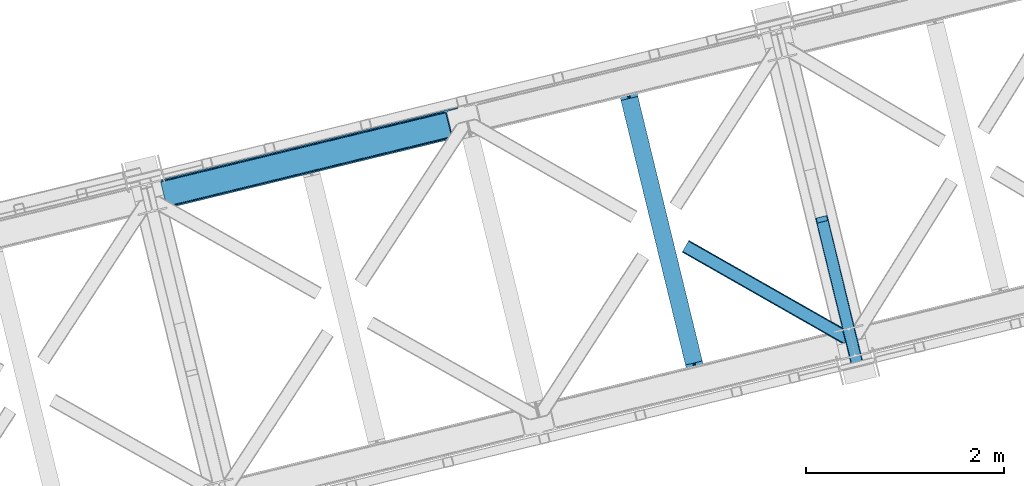
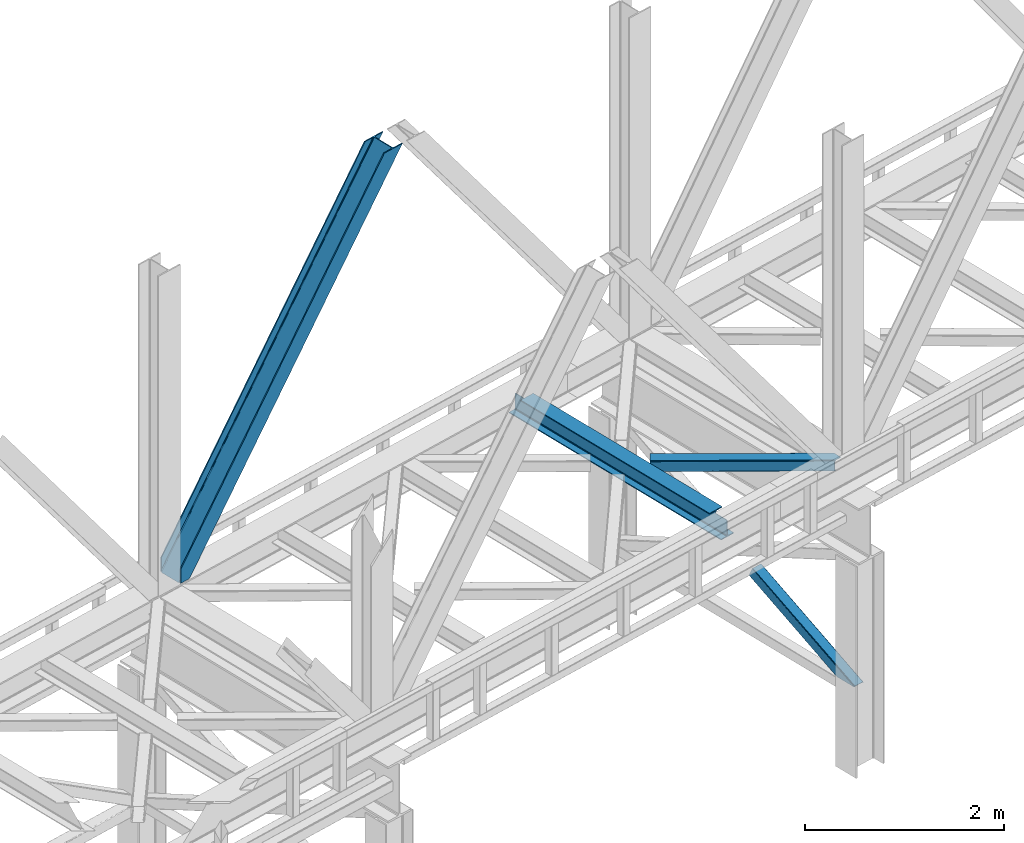
# One storey, part 54 of 93: 3 members, 1 beam.
"""IFC4 building model written with IfcOpenShell, lengths in millimetres."""

from ifc_helpers import new_model, entity, si_unit, converted_unit, derived_unit, direction, frame, origin, place, context, subcontext, project, spatial, triangles, polygons, material, type_object, element, save


model = new_model("IFC4")

# Units and contexts
model_context = context("Model", 3, precision=0.01, world=origin(), true_north=direction((6.12303176911189e-17, 1.0)))
plan_context = context("Plan", 3, precision=0.01, world=origin(), true_north=direction((6.12303176911189e-17, 1.0)))
body_context = subcontext(model_context, "Body", "Model", "MODEL_VIEW")
ifc_project = project(units=[si_unit("LENGTHUNIT", "METRE", prefix="MILLI"), si_unit("AREAUNIT", "SQUARE_METRE"), si_unit("VOLUMEUNIT", "CUBIC_METRE"), converted_unit("PLANEANGLEUNIT", "DEGREE", entity("IfcRatioMeasure", 0.0174532925199433), si_unit("PLANEANGLEUNIT", "RADIAN"), dimensions=[0, 0, 0, 0, 0, 0, 0]), si_unit("MASSUNIT", "GRAM", prefix="KILO"), derived_unit("MASSDENSITYUNIT", [(si_unit("MASSUNIT", "GRAM", prefix="KILO"), 1), (si_unit("LENGTHUNIT", "METRE"), -3)]), derived_unit("MOMENTOFINERTIAUNIT", [(si_unit("LENGTHUNIT", "METRE"), 4)]), si_unit("TIMEUNIT", "SECOND"), si_unit("FREQUENCYUNIT", "HERTZ"), si_unit("THERMODYNAMICTEMPERATUREUNIT", "DEGREE_CELSIUS"), derived_unit("THERMALTRANSMITTANCEUNIT", [(si_unit("MASSUNIT", "GRAM", prefix="KILO"), 1), (si_unit("THERMODYNAMICTEMPERATUREUNIT", "KELVIN"), -1), (si_unit("TIMEUNIT", "SECOND"), -3)]), derived_unit("VOLUMETRICFLOWRATEUNIT", [(si_unit("LENGTHUNIT", "METRE"), 3), (si_unit("TIMEUNIT", "SECOND"), -1)]), derived_unit("MASSFLOWRATEUNIT", [(si_unit("MASSUNIT", "GRAM", prefix="KILO"), 1), (si_unit("TIMEUNIT", "SECOND"), -1)]), derived_unit("ROTATIONALFREQUENCYUNIT", [(si_unit("TIMEUNIT", "SECOND"), -1)]), si_unit("ELECTRICCURRENTUNIT", "AMPERE"), si_unit("ELECTRICVOLTAGEUNIT", "VOLT"), si_unit("POWERUNIT", "WATT"), si_unit("FORCEUNIT", "NEWTON", prefix="KILO"), si_unit("ILLUMINANCEUNIT", "LUX"), si_unit("LUMINOUSFLUXUNIT", "LUMEN"), si_unit("LUMINOUSINTENSITYUNIT", "CANDELA"), derived_unit("USERDEFINED", [(si_unit("MASSUNIT", "GRAM", prefix="KILO"), -1), (si_unit("LENGTHUNIT", "METRE"), -2), (si_unit("TIMEUNIT", "SECOND"), 3), (si_unit("LUMINOUSFLUXUNIT", "LUMEN"), 1)]), derived_unit("LINEARVELOCITYUNIT", [(si_unit("LENGTHUNIT", "METRE"), 1), (si_unit("TIMEUNIT", "SECOND"), -1)]), si_unit("PRESSUREUNIT", "PASCAL"), derived_unit("USERDEFINED", [(si_unit("LENGTHUNIT", "METRE"), -2), (si_unit("MASSUNIT", "GRAM", prefix="KILO"), 1), (si_unit("TIMEUNIT", "SECOND"), -2)]), derived_unit("LINEARFORCEUNIT", [(si_unit("MASSUNIT", "GRAM", prefix="KILO"), 1), (si_unit("LENGTHUNIT", "METRE"), 1), (si_unit("TIMEUNIT", "SECOND"), -2), (si_unit("LENGTHUNIT", "METRE"), -1)]), derived_unit("PLANARFORCEUNIT", [(si_unit("MASSUNIT", "GRAM", prefix="KILO"), 1), (si_unit("LENGTHUNIT", "METRE"), 1), (si_unit("TIMEUNIT", "SECOND"), -2), (si_unit("LENGTHUNIT", "METRE"), -2)])], contexts=[model_context, plan_context])

# Site, building, storey
site_placement = place(None, origin())
site = spatial("IfcSite", under=ifc_project, at=site_placement, CompositionType="ELEMENT")
building_placement = place(site_placement, origin())
building = spatial("IfcBuilding", under=site, at=building_placement, CompositionType="ELEMENT")
storey_placement = place(building_placement, frame((0.0, 0.0, 15900.0)))
storey = spatial("IfcBuildingStorey", under=building, at=storey_placement, CompositionType="ELEMENT", Elevation=15900.0)

# Beam
ifc_material = material(Name="Metal painted (White)")
beam_type = type_object("IfcBeamType", PredefinedType="BEAM")
beam_placement = place(storey_placement, frame((-31800.9223740424, 10034.8935281145, 3441.0)))
element("IfcBeam", 1, at=beam_placement, inside=storey, type_object=beam_type, material=ifc_material, ObjectType="Steel Beam", PredefinedType="BEAM", context=body_context, shape_type="Tessellation", body=[
    polygons([(900.98534618944, 41.4445662733081, 11.000000000004), (900.98534618944, 41.4445662733081, 2.16573425859679e-12), (170.021610174761, 3040.13999372697, 2.16573425859679e-12), (170.021610174761, 3040.13999372697, 11.000000000004), (834.919806235814, 25.3403919499634, 11.000000000004), (103.956070221139, 3024.03581940362, 11.000000000004), (828.971056214522, 23.8903211957374, 12.2179274798217), (98.007320199847, 3022.5857486494, 12.2179274798217), (823.927949458418, 22.6610105689194, 15.6862915010192), (92.9642134437384, 3021.35643802258, 15.6862915010192), (820.558253255246, 21.8396114687119, 20.8770650821657), (89.5945172405668, 3020.53503892237, 20.8770650821657), (819.374973305552, 21.5511744621184, 27.0000000000047), (88.4112372908766, 3020.24660191578, 27.0000000000047), (81.6103728838888, 3018.58881926485, 27.0000000000047), (81.6103728838844, 3018.58881926485, 203.000000000006), (88.4112372908766, 3020.24660191578, 203.000000000006), (0.0, 2998.69542745366, 2.16573425859679e-12), (4.33146851719357e-12, 2998.69542745366, 10.9999999999997), (66.0655399536259, 3014.799601777, 11.000000000004), (72.0142899749184, 3016.24967253123, 12.2179274798217), (77.0573967310183, 3017.47898315805, 15.6862915010192), (80.4270929342029, 3018.30038225825, 20.8770650821613), (819.374973305556, 21.5511744621184, 203.000000000006), (812.574108898559, 19.8933918111876, 203.000000000006), (812.574108898568, 19.8933918111876, 27.0000000000047), (811.390828948882, 19.6049548045963, 20.8770650821613), (808.021132745698, 18.7835557043866, 15.6862915010192), (802.978025989598, 17.5542450775685, 12.2179274798217), (797.029275968305, 16.1041743233403, 11.000000000004), (730.963736014684, -2.16573425859679e-12, 10.9999999999997), (730.963736014679, -2.16573425859679e-12, 2.16573425859679e-12), (779.675212882766, 184.415062601692, 203.069791966819), (128.020401343517, 2857.75452019162, 203.000000000006), (128.243282132667, 2856.84017775719, 203.617301946336), (128.25619637719, 2856.7871977843, 217.000003693143), (779.530009633841, 185.010597404072, 217.000003676718), (779.530880241731, 185.007025963192, 204.00000679514), (772.96491171832, 182.385463974439, 203.006342981529), (772.742064056778, 183.299815969774, 203.617301946336), (772.729149812254, 183.352795942665, 217.000003693143), (121.455336555608, 2855.12939632289, 217.000003676718), (121.45446594771, 2855.13296776377, 204.00000679514), (121.31016635866, 2855.72494066435, 203.076120467494), (121.219536936524, 2856.09673754069, 203.000000000006), (780.713494357868, 185.298194377514, 223.122939328039), (784.082490766543, 186.122464201391, 228.313710402595), (789.125126170563, 187.353708426697, 231.782072735464), (795.073705041266, 188.804481281379, 232.999999602236), (861.13915590679, 204.909021065313, 232.999999283132), (861.137682570352, 204.915065042186, 243.999994005812), (691.116301666435, 163.469558245295, 243.999994827032), (691.117775002873, 163.463514268422, 233.000000104353), (757.183225868396, 179.568054052358, 232.999999785253), (763.132130996735, 181.017488520584, 231.782072861012), (768.175695503857, 182.244921343716, 228.313710479427), (771.546082413602, 183.063487001146, 223.12293937232), (120.271851831572, 2854.84179934945, 223.122939328039), (116.902855422893, 2854.01752952557, 228.313710402595), (111.860220018882, 2852.78628530027, 231.782072735464), (105.91164114817, 2851.33551244559, 232.999999602236), (39.8461902826462, 2835.23097266165, 232.999999283128), (39.8476636190837, 2835.22492868478, 243.999994005812), (209.869044523001, 2876.67043548167, 243.999994827032), (209.867571186563, 2876.67647945854, 233.000000104357), (143.802120321035, 2860.57193967461, 232.999999785253), (137.853215192714, 2859.12250520638, 231.782072861012), (132.809650685579, 2857.89507238325, 228.313710479427), (129.439263775843, 2857.07650672582, 223.12293937232)], [[[1, 2, 3, 4]], [[5, 1, 4, 6]], [[7, 5, 6, 8]], [[9, 7, 8, 10]], [[11, 9, 10, 12]], [[13, 11, 12, 14]], [[15, 16, 17, 14, 12, 10, 8, 6, 4, 3, 18, 19, 20, 21, 22, 23]], [[13, 24, 25, 26, 27, 28, 29, 30, 31, 32, 2, 1, 5, 7, 9, 11]], [[2, 32, 18, 3]], [[32, 31, 19, 18]], [[31, 30, 20, 19]], [[27, 26, 15, 23]], [[28, 27, 23, 22]], [[29, 28, 22, 21]], [[30, 29, 21, 20]], [[33, 24, 13, 14, 17, 34, 35, 36, 37, 38]], [[25, 39, 40, 41, 42, 43, 44, 16, 15, 26]], [[39, 25, 24, 33]], [[45, 34, 17, 16]], [[41, 40, 38, 37, 46, 47, 48, 49, 50, 51, 52, 53, 54, 55, 56, 57]], [[42, 58, 59, 60, 61, 62, 63, 64, 65, 66, 67, 68, 69, 36, 35, 43]], [[46, 37, 36, 69]], [[47, 46, 69, 68]], [[48, 47, 68, 67]], [[49, 48, 67, 66]], [[50, 49, 66, 65]], [[51, 50, 65, 64]], [[52, 51, 64, 63]], [[53, 52, 63, 62]], [[54, 53, 62, 61]], [[55, 54, 61, 60]], [[56, 55, 60, 59]], [[57, 56, 59, 58]], [[41, 57, 58, 42]]], closed=False),
])

# Members
member_type_1 = type_object("IfcMemberType", PredefinedType="BRACE")
member_1_placement = place(storey_placement, frame((-36411.1844787598, 11783.169140625, 3694.99929199219)))
element("IfcMember", 2, at=member_1_placement, inside=storey, type_object=member_type_1, ObjectType="Steel Vertical Brace", PredefinedType="BRACE", context=body_context, shape_type="Tessellation", body=[
    triangles([(58.5289855957017, 27.9227142333984, 0.0), (60.4544494628863, 20.0173828124989, 0.0), (59.0963928222627, 20.9719757080074, 0.827856445310317), (58.9708190917954, 19.7941406249993, 1.13481445312209), (72.0351379394488, 11.6585906982418, 0.0), (71.2235595703096, 13.9003143310547, 30.2981506347642), (70.0794433593765, 15.4013854980458, 25.0194030761704), (72.0351379394488, 11.6585906982418, 170.803527832031), (71.7537597656265, 12.6201599121086, 41.9881347656228), (71.7537597656265, 12.6201599121086, 170.743066406249), (70.2445495605425, 15.5234710693348, 0.0), (68.6423217773408, 17.2884796142571, 18.377947998044), (66.9517272949233, 18.0907562255852, 14.9735046386704), (67.1168334960894, 18.4186431884755, 0.0), (63.12870483398, 19.9092498779282, 7.26932373046657), (63.12870483398, 19.9092498779282, 0.0), (2824.67177124023, 683.673385620117, 3911.00081176758), (2919.44040527344, 706.773138427734, 3911.00081176758), (2937.07653808594, 722.50938720703, 3911.00081176758), (2933.70465087891, 715.67724609375, 3911.00081176758), (2937.11839599609, 729.608953857422, 3911.00081176758), (2927.51200561523, 710.150839233398, 3911.00081176758), (2827.75065307617, 671.042761230468, 3911.00081176758), (74.8768249511704, 0.0, 170.803527832031), (74.8768249511704, 0.0, 0.0), (192.937060546872, 28.7784759521473, 0.0), (3071.52647094726, 730.46471557617, 3911.00081176758), (3068.44758911133, 743.095339965819, 3911.00081176758), (189.858178710936, 41.4091003417961, 0.0), (2973.67895507813, 719.994424438475, 3911.00081176758), (95.0918701171831, 18.308184814452, 0.0), (2964.95855712891, 719.279351806639, 3911.00081176758), (86.3691467285171, 17.5931121826161, 0.0), (2956.9171875, 721.336203002929, 3911.00081176758), (78.3277770996065, 19.648800659179, 0.0), (2950.77802734375, 725.848718261717, 3911.00081176758), (72.190942382811, 24.1624786376942, 0.0), (2947.47590332031, 732.134381103515, 3911.00081176758), (68.8888183593735, 30.4481414794918, 0.0), (2892.29555053711, 958.506610107421, 3911.00081176758), (13.7084655761719, 256.820370483398, 0.0), (2892.33508300781, 965.606176757812, 3911.00081176758), (13.7456726074233, 263.919937133789, 0.0), (2895.7092956543, 972.438317871092, 3911.00081176758), (17.1198852539019, 270.752078247069, 0.0), (2901.90194091797, 977.964724731444, 3911.00081176758), (23.3125305175781, 276.277322387694, 0.0), (2909.97354125977, 981.342425537108, 3911.00081176758), (31.3864562988238, 279.656185913085, 0.0), (3004.73984985351, 1004.44334106445, 3911.00081176758), (126.150439453122, 302.755938720702, 0.0), (3001.66096801758, 1017.07280273437, 3911.00081176758), (123.071557617186, 315.386563110351, 0.0), (2881.93804321289, 955.981182861327, 3911.00081176758), (3.34630737304542, 254.294943237304, 0.0), (2872.49443359375, 966.78052368164, 3911.00081176758), (2864.45306396484, 968.836212158203, 3911.00081176758), (2757.88747558594, 957.650848388672, 3911.00081176758), (2855.73499145508, 968.121139526367, 3911.00081176758), (2760.96635742187, 945.020223999023, 3911.00081176758), (2878.63359375, 962.265682983398, 3911.00081176758), (5.01364746093896, 286.608087158202, 170.803527832031), (5.01364746093896, 286.608087158202, 0.0), (7.85533447265334, 274.94949645996, 170.803527832031), (8.0460205078125, 273.966998291015, 170.743066406249), (8.0460205078125, 273.966998291015, 41.9881347656228), (7.85533447265334, 274.94949645996, 0.0), (3.74395751953125, 263.525775146483, 0.0), (6.59959716796584, 266.686047363281, 0.0), (8.04369506835792, 270.693942260741, 0.0), (1.42084350586083, 262.199111938477, 0.0), (3.74395751953125, 263.525775146483, 7.26932373046657), (6.30194091796875, 266.898825073242, 14.9735046386704), (7.43442993163626, 268.391757202147, 18.377947998044), (8.16694335937063, 272.585687255858, 30.2981506347642), (7.84138183593313, 270.727661132813, 25.0194030761704), (0.0, 261.715420532226, 1.13481445312209), (0.65344848632958, 260.728271484375, 0.827856445310317)], [[1, 2, 3], [4, 3, 2], [5, 6, 7], [5, 8, 9], [10, 9, 8], [9, 6, 5], [11, 12, 13], [11, 7, 12], [14, 13, 15], [15, 4, 2], [2, 16, 15], [15, 16, 14], [13, 14, 11], [7, 11, 5], [17, 18, 10], [9, 10, 18], [19, 3, 15], [15, 20, 19], [12, 20, 13], [15, 13, 20], [3, 4, 15], [19, 21, 1], [1, 3, 19], [6, 20, 7], [6, 22, 20], [12, 7, 20], [18, 22, 9], [6, 9, 22], [8, 17, 10], [23, 8, 24], [8, 23, 17], [25, 24, 5], [8, 5, 24], [23, 26, 27], [26, 23, 24], [25, 26, 24], [28, 27, 29], [26, 29, 27], [30, 28, 29], [29, 31, 30], [32, 30, 31], [31, 33, 32], [34, 32, 33], [33, 35, 34], [36, 34, 35], [35, 37, 36], [38, 36, 37], [37, 39, 38], [40, 38, 39], [39, 41, 40], [42, 40, 43], [41, 43, 40], [44, 42, 45], [43, 45, 42], [46, 44, 47], [45, 47, 44], [48, 46, 49], [47, 49, 46], [50, 48, 51], [49, 51, 48], [52, 50, 53], [51, 53, 50], [21, 54, 1], [55, 1, 54], [54, 21, 40], [20, 22, 32], [18, 23, 27], [17, 23, 18], [22, 18, 30], [21, 19, 36], [19, 20, 34], [56, 46, 57], [58, 59, 52], [59, 57, 48], [58, 60, 59], [56, 61, 44], [61, 54, 42], [40, 21, 38], [30, 32, 22], [36, 19, 34], [32, 34, 20], [36, 38, 21], [27, 30, 18], [27, 28, 30], [48, 57, 46], [44, 61, 42], [40, 42, 54], [44, 46, 56], [48, 52, 59], [52, 48, 50], [58, 53, 62], [58, 52, 53], [53, 63, 62], [64, 58, 62], [60, 64, 65], [64, 60, 58], [59, 60, 65], [65, 66, 59], [67, 64, 62], [62, 63, 67], [11, 35, 5], [68, 41, 55], [69, 70, 43], [69, 43, 68], [55, 71, 68], [67, 63, 47], [67, 45, 70], [55, 39, 1], [37, 14, 16], [2, 1, 16], [16, 1, 39], [11, 14, 37], [25, 5, 33], [39, 55, 41], [49, 47, 63], [43, 70, 45], [47, 45, 67], [43, 41, 68], [53, 49, 63], [53, 51, 49], [31, 25, 33], [35, 11, 37], [39, 37, 16], [35, 33, 5], [31, 26, 25], [26, 31, 29], [72, 68, 71], [69, 68, 72], [70, 69, 73], [73, 74, 70], [67, 75, 66], [67, 70, 76], [76, 75, 67], [64, 67, 66], [66, 65, 64], [74, 76, 70], [72, 73, 69], [71, 77, 72], [78, 61, 72], [61, 56, 74], [74, 73, 61], [73, 72, 61], [57, 59, 66], [66, 75, 57], [56, 75, 76], [75, 56, 57], [76, 74, 56], [72, 77, 78], [54, 61, 55], [78, 55, 61], [71, 55, 78], [78, 77, 71]]),
])
member_type_2 = type_object("IfcMemberType", PredefinedType="BRACE")
member_2_placement = place(storey_placement, frame((-29797.8395349544, 10185.5919736946, 970.499999998947)))
element("IfcMember", 3, at=member_2_placement, inside=storey, type_object=member_type_2, ObjectType="Steel Vertical Brace", PredefinedType="BRACE", context=body_context, shape_type="Tessellation", body=[
    polygons([(310.156875969819, 236.659699185643, 1.04388391264365e-09), (309.042346364983, 243.803283956979, 1.04171817838505e-09), (4.57230123624037, 1492.85694714149, 603.530503671959), (4.28876445601824, 1491.44877039324, 606.301796687595), (309.28077373894, 250.147759710235, 1.04171817838505e-09), (5.99595206163126, 1494.33917875157, 601.181114896122), (310.835859685349, 254.727237524781, 1.05038111541944e-09), (8.34297899943964, 1495.6698088973, 599.611303503951), (313.470856465754, 256.844533416439, 1.04171817838505e-09), (11.2560684742533, 1496.64626120118, 599.060059049496), (366.444630080976, 5.74560241384962, 1.00706643024751e-09), (14.4533090982474, 1449.74988433501, 697.72873436856), (411.597614338037, 280.763968808463, 1.04171817838505e-09), (109.38282634654, 1520.5656965932, 599.060059049498), (425.485457020336, 274.46076918091, 1.03522097560926e-09), (485.1720650288, 29.6032616237767, 9.24768528420827e-10), (481.013627176896, 28.589598401482, 9.24768528420827e-10), (480.11622088353, 33.4542552937189, 9.72414682109957e-10), (423.828466772369, 264.36835206551, 1.03305524135067e-09), (421.530657217855, 271.223499830257, 1.03522097560926e-09), (418.399388388632, 276.746576483303, 1.03738670986786e-09), (414.911367578928, 280.096743671033, 1.04171817838505e-09), (367.886495613074, 1.01366322182258, 9.29099996938021e-10), (363.72805776111, 2.16573425859679e-12, 5.76085312786745e-10), (304.041449752647, 244.857507557116, 1.03522097560926e-09), (302.926920147819, 252.001092328463, 1.04171817838505e-09), (303.165347521772, 258.345568081722, 1.03738670986786e-09), (304.720433468181, 262.925045896265, 1.04604964690225e-09), (307.355430248582, 265.042341787917, 1.04388391264365e-09), (413.254604586004, 290.856385923862, 1.04604964690225e-09), (416.568357826896, 290.18916078644, 1.04604964690225e-09), (420.056378636591, 286.83899359871, 1.04171817838505e-09), (423.187647465818, 281.315916945664, 1.04171817838505e-09), (112.418486893027, 1521.03931504355, 599.611303503942), (115.114566711319, 1520.93799552464, 601.181114896124), (117.060612089113, 1520.27716301478, 603.530503671961), (117.960355258576, 1519.15742327311, 606.301796687595), (128.124899900797, 1477.45853721488, 697.72873436856), (127.841363120579, 1476.05036046663, 700.50002738419), (126.417712295197, 1474.56812885656, 702.849416160034), (124.070685357388, 1473.23749871082, 704.419227552215), (121.157595882579, 1472.26104640694, 704.970472006657), (23.0308380102839, 1448.34161101491, 704.970472006657), (19.9951774638007, 1447.86799256457, 704.419227552218), (17.2990976455048, 1447.96931208348, 702.849416160034), (15.3530522677154, 1448.63014459335, 700.500027384193), (112.866478355649, 1523.16444199718, 595.439190230451), (6.9673040182264, 1497.35039786123, 595.439190230448), (4.05421454341274, 1496.37394555734, 595.990434684895), (1.70718760560436, 1495.04331541162, 597.56024607707), (0.283536780226461, 1493.56108380154, 599.909634852913), (4.33146851719357e-12, 1492.15290705329, 602.680927868548), (10.9696570891342, 1447.15113893104, 701.349603187608), (11.8694002586022, 1446.03139918938, 704.120896203242), (13.8154456363959, 1445.37056667951, 706.470284979081), (16.5115254546918, 1445.2692471606, 708.040096371263), (19.547186001175, 1445.74286561094, 708.591340825705), (125.446360338597, 1471.55690974689, 708.591340825705), (128.359449813407, 1472.53336205077, 708.040096371265), (130.706476751211, 1473.8639921965, 706.470284979081), (132.130127576602, 1475.34622380658, 704.120896203244), (132.413664356819, 1476.75440055483, 701.349603187608), (121.444007267694, 1521.75616867708, 602.680927868548), (120.54426409823, 1522.87590841874, 599.909634852913), (118.598218720423, 1523.53674092861, 597.560246077077), (115.902138902132, 1523.63806044752, 595.990434684895), (375.386682458811, 2.84191311588703, 6.51916727653314), (372.638718264457, 2.17206777061844, 5.2249222388966), (369.890754070111, 1.50222242536501, 3.93067720123841), (368.373326648029, 1.13233343716383, 0.954754934343811), (480.407239661998, 28.441785029781, 0.783330976602792), (478.425418155212, 27.9586950702395, 3.34344663920135), (476.487815341744, 27.4863838850221, 5.84644062407408), (473.513440331098, 26.7613485079113, 6.51916727653314), (485.172065028804, 29.6032616237637, 2.10033831597304), (484.033820990588, 29.3258025970721, 5.22492223888794), (482.895576952369, 29.048343570374, 8.34950616180717), (480.147612758023, 28.3784982251097, 9.64375119945237), (477.399648563668, 27.7086528798498, 10.9379962370932), (371.500474226241, 1.89460874392469, 10.9379962370954), (368.752510031891, 1.22476339866259, 9.6437511994502), (366.004545837554, 0.554918053404833, 8.34950616180934), (364.866301799325, 0.277459026702417, 5.2249222388901), (363.72805776111, 4.33146851719357e-12, 2.10033831597304)], [[[1, 2, 3, 4]], [[2, 5, 6, 3]], [[5, 7, 8, 6]], [[7, 9, 10, 8]], [[11, 1, 4, 12]], [[9, 13, 14, 10]], [[15, 16, 17, 18, 19, 20, 21, 22, 13, 9, 7, 5, 2, 1, 11, 23, 24, 25, 26, 27, 28, 29, 30, 31, 32, 33]], [[47, 48, 49, 50, 51, 52, 53, 54, 55, 56, 57, 58, 59, 60, 61, 62, 63, 64, 65, 66], [10, 14, 34, 35, 36, 37, 38, 39, 40, 41, 42, 43, 44, 45, 46, 12, 4, 3, 6, 8]], [[13, 22, 34, 14]], [[22, 21, 35, 34]], [[21, 20, 36, 35]], [[20, 19, 37, 36]], [[19, 18, 38, 37]], [[44, 67, 68]], [[45, 68, 69]], [[46, 69, 70]], [[46, 11, 12]], [[11, 70, 23]], [[11, 46, 70]], [[69, 46, 45]], [[68, 45, 44]], [[67, 44, 43]], [[71, 18, 17]], [[39, 72, 40]], [[40, 73, 41]], [[73, 74, 42, 41]], [[73, 40, 72]], [[72, 39, 71]], [[39, 18, 71]], [[18, 39, 38]], [[42, 74, 67, 43]], [[16, 75, 76, 77, 78, 79, 80, 81, 82, 83, 84, 24, 23, 70, 69, 68, 67, 74, 73, 72, 71, 17]], [[29, 28, 49, 48]], [[28, 27, 50, 49]], [[27, 26, 51, 50]], [[26, 25, 52, 51]], [[47, 30, 29, 48]], [[15, 33, 64, 63]], [[33, 32, 65, 64]], [[32, 31, 66, 65]], [[31, 30, 47, 66]], [[24, 84, 53, 52, 25]], [[75, 16, 15, 63, 62]], [[53, 83, 54]], [[54, 82, 55]], [[55, 81, 56]], [[56, 80, 57]], [[80, 56, 81]], [[81, 55, 82]], [[82, 54, 83]], [[83, 53, 84]], [[80, 79, 58, 57]], [[59, 79, 78]], [[60, 78, 77]], [[61, 77, 76]], [[62, 76, 75]], [[76, 62, 61]], [[77, 61, 60]], [[78, 60, 59]], [[79, 59, 58]]], closed=True),
])
member_type_3 = type_object("IfcMemberType", PredefinedType="BRACE")
member_3_placement = place(storey_placement, frame((-31143.9850524902, 10419.121005249, 3510.06058044434)))
element("IfcMember", 4, at=member_3_placement, inside=storey, type_object=member_type_3, ObjectType="Steel Horizontal Brace", PredefinedType="BRACE", context=body_context, shape_type="Tessellation", body=[
    triangles([(1627.55879516602, 3.72651672363281, 138.64386291504), (1637.03728637695, 6.03684082031214, 139.974014282227), (8.68319091796729, 933.153506469725, 140.385617065429), (5.36711425781323, 927.332931518555, 139.053140258788), (1619.52672729492, 1.767333984375, 134.851071166991), (2.5579833984375, 922.39951171875, 135.260348510743), (1614.15728759766, 0.459274291992188, 129.174673461916), (0.681353759766353, 919.104364013672, 129.581625366212), (1612.27135620117, 0.0, 122.477407836916), (0.0209289550766698, 917.947457885743, 122.884359741212), (1612.27135620117, 0.0, 17.478002929689), (0.0, 917.957922363281, 17.8849548339858), (1676.30930786133, 104.50408630371, 139.978665161132), (1696.76387329102, 20.5952545166019, 139.964712524416), (60.6335083007798, 1024.39909973144, 140.385617065429), (1671.04451293945, 126.106256103516, 129.176998901366), (1670.60965576172, 127.886380004882, 122.482058715821), (68.6330200195298, 1038.45173034668, 129.581625366212), (69.2911193847649, 1039.60979919434, 122.884359741212), (1672.27932128906, 121.037960815429, 134.853396606446), (66.7540649414077, 1035.15425720215, 135.260348510743), (1674.13037109375, 113.452377319336, 138.646188354491), (63.9472595214829, 1030.21967468262, 139.053140258788), (1670.60965576172, 127.886380004882, 17.4814910888672), (69.2678649902336, 1039.62026367188, 17.8849548339858), (0.658099365235103, 919.117153930663, 11.1876892089858), (1614.54563598633, 0.554617309569949, 10.8481750488281), (1543.47090454102, 41.4207275390618, 9.46221313476417), (2.53240356445167, 922.413464355468, 5.51129150390625), (1541.24313354492, 46.3401947021484, 5.1229431152351), (1542.09424438477, 42.8473846435536, 8.46227416992042), (1543.13836669922, 41.764892578125, 9.22036743164063), (1542.78257446289, 42.1334747314449, 8.96224365234229), (1542.42678222656, 42.5032196044922, 8.7041198730476), (1615.02235107422, 0.669726562498909, 9.46221313476417), (1539.39208374023, 53.9257781982415, 1.33015136718677), (5.3415344238274, 927.348046875, 1.71733703613427), (1537.2108215332, 62.8740692138672, 0.0), (8.65528564453052, 933.168621826171, 0.384860229492915), (1503.01290893555, 203.171319580078, 0.0209289550766698), (60.6079284667976, 1024.41537780762, 0.384860229492915), (1634.21885375976, 5.34967346191297, 9.46221313476417), (1539.04326782226, 59.5847351074208, 9.46221313476417), (1538.54329833984, 60.0172668457035, 9.38547363281396), (1538.10146484375, 60.9648834228519, 9.07851562499854), (1537.65498046875, 61.9218017578114, 8.76923217773583), (1537.21314697266, 62.8694183349598, 8.46227416992042), (8.80643920898365, 933.430233764648, 8.71690979004052), (1537.10850219726, 63.299624633788, 8.39483642578125), (5.99730834960792, 928.496813964843, 12.5108642578125), (1629.43309936523, 4.18230285644495, 12.101586914061), (1534.93189086914, 72.2269866943352, 7.00073547363354), (12.1201904296868, 939.25080871582, 7.38559570312646), (1624.06365966797, 2.87424316406214, 17.7791473388679), (4.12300415039135, 925.199340820313, 18.1884246826157), (1622.17772827148, 2.41496887206995, 24.4764129638679), (3.46490478515625, 924.041271972656, 24.8845275878921), (1622.17772827148, 2.41496887206995, 115.477835083009), (3.4811828613274, 924.030807495117, 115.884786987306), (1629.43309936523, 4.18230285644495, 127.849172973634), (1637.46749267578, 6.14148559570276, 131.641964721679), (1624.06365966797, 2.87424316406214, 122.172775268555), (1646.94365844726, 8.45180969238208, 132.972116088866), (1696.76387329102, 20.5952545166019, 132.965139770509), (4.14393310546802, 925.187713623047, 122.582052612306), (6.02056274413917, 928.484024047852, 128.258450317382), (8.8296936035149, 933.417443847657, 132.053567504881), (12.1457702636726, 939.236856079102, 133.386044311523), (1678.59056396484, 95.1500061035149, 132.976766967775), (57.1686035156235, 1018.3169128418, 133.386044311523), (1505.29183959961, 193.818402099609, 7.01933898925927), (57.1453491210923, 1018.33086547852, 7.38559570312646), (68.6097656249985, 1038.46452026367, 11.1876892089858), (63.2682312011711, 1029.08369750976, 12.5108642578125), (65.1471862792969, 1032.38000793457, 18.1884246826157), (65.8076110839829, 1033.5369140625, 24.8845275878921), (66.7308105468765, 1035.16820983887, 5.51129150390625), (63.9216796875007, 1030.23479003906, 1.71733703613427), (60.4591003417954, 1024.15027770996, 8.71690979004052), (63.2914855957024, 1029.07090759277, 128.258450317382), (65.8262145996086, 1033.52761230469, 115.884786987306), (65.1681152343735, 1032.36954345703, 122.582052612306), (60.4823547363267, 1024.13748779297, 132.053567504881), (1672.89091186523, 118.533462524414, 24.4799011230461), (1672.89091186523, 118.533462524414, 115.48016052246), (1676.40930175781, 104.098297119141, 131.644290161134), (1674.56057739258, 111.685043334961, 127.85382385254), (1673.32344360352, 116.753338623046, 122.17742614746), (1674.56057739258, 111.685043334961, 12.1039123535156), (1675.66283569336, 107.15973815918, 9.46221313476417), (1671.24450073242, 125.287701416015, 9.46221313476417), (1673.32344360352, 116.753338623046, 17.7826354980461), (1671.13520507812, 125.737673950194, 10.8516632080064), (1498.13646240234, 223.174749755859, 8.46227416992042), (1503.02686157227, 203.10969543457, 8.46227416992042), (1498.98292236328, 219.705194091797, 5.14968566894458), (1503.11522827148, 202.749252319336, 8.40646362304688), (1500.83164672851, 212.119610595702, 1.35456848144531), (1498.15274047852, 223.423571777343, 8.84480895996239), (1499.14802856445, 223.244512939453, 9.46221313476417), (1498.47830200195, 223.365435791015, 9.04595947265625), (1503.58496704102, 205.049111938477, 9.46221313476417), (1502.96640014648, 203.975921630859, 8.81574096679833)], [[1, 2, 3], [3, 4, 1], [5, 1, 4], [4, 6, 5], [7, 5, 6], [6, 8, 7], [9, 7, 8], [8, 10, 9], [11, 9, 12], [10, 12, 9], [2, 13, 3], [2, 14, 13], [15, 3, 13], [16, 17, 18], [19, 18, 17], [20, 16, 21], [18, 21, 16], [22, 20, 23], [21, 23, 20], [13, 22, 15], [23, 15, 22], [17, 24, 25], [25, 19, 17], [26, 27, 11], [27, 26, 28], [26, 29, 30], [30, 31, 26], [32, 26, 33], [32, 28, 26], [26, 34, 33], [26, 31, 34], [28, 35, 27], [36, 30, 29], [29, 37, 36], [38, 36, 37], [37, 39, 38], [11, 12, 26], [40, 38, 39], [39, 41, 40], [42, 35, 43], [28, 43, 35], [32, 44, 43], [33, 45, 44], [34, 46, 45], [31, 47, 46], [46, 34, 31], [45, 33, 34], [44, 32, 33], [43, 28, 32], [45, 48, 44], [48, 45, 46], [47, 48, 46], [47, 49, 48], [50, 51, 43], [43, 48, 50], [43, 44, 48], [51, 42, 43], [48, 49, 52], [52, 53, 48], [54, 51, 50], [50, 55, 54], [56, 54, 55], [55, 57, 56], [58, 56, 57], [57, 59, 58], [60, 61, 1], [5, 60, 1], [5, 7, 62], [60, 5, 62], [62, 7, 9], [61, 2, 1], [63, 2, 61], [14, 63, 64], [63, 14, 2], [62, 9, 58], [56, 11, 54], [11, 58, 9], [11, 27, 54], [11, 56, 58], [35, 54, 27], [51, 54, 35], [42, 51, 35], [62, 58, 65], [59, 65, 58], [60, 62, 66], [65, 66, 62], [61, 60, 67], [66, 67, 60], [63, 61, 68], [67, 68, 61], [69, 63, 68], [63, 69, 64], [68, 70, 69], [52, 71, 53], [72, 53, 71], [73, 74, 75], [76, 19, 25], [73, 75, 25], [73, 77, 74], [75, 76, 25], [74, 77, 78], [72, 41, 39], [41, 79, 78], [79, 41, 72], [79, 74, 78], [18, 80, 21], [81, 19, 76], [19, 82, 18], [82, 19, 81], [18, 82, 80], [15, 70, 3], [23, 21, 80], [80, 83, 23], [83, 70, 15], [15, 23, 83], [50, 37, 29], [39, 53, 72], [39, 48, 53], [48, 39, 37], [50, 48, 37], [57, 12, 10], [26, 55, 50], [29, 26, 50], [55, 26, 12], [57, 55, 12], [4, 66, 6], [3, 70, 68], [68, 67, 3], [67, 66, 4], [4, 3, 67], [8, 6, 66], [10, 59, 57], [65, 10, 8], [10, 65, 59], [65, 8, 66], [84, 85, 76], [81, 76, 85], [86, 69, 70], [70, 83, 86], [87, 86, 83], [83, 80, 87], [88, 87, 80], [80, 82, 88], [85, 88, 82], [82, 81, 85], [87, 20, 22], [89, 90, 91], [20, 87, 88], [86, 87, 22], [86, 13, 69], [14, 69, 13], [69, 14, 64], [86, 22, 13], [24, 85, 84], [91, 92, 89], [92, 24, 84], [93, 92, 91], [93, 24, 92], [17, 85, 24], [88, 16, 20], [17, 16, 88], [85, 17, 88], [40, 71, 52], [94, 95, 96], [95, 97, 40], [71, 40, 97], [95, 98, 96], [95, 40, 98], [38, 40, 52], [38, 52, 49], [47, 38, 49], [31, 30, 47], [47, 36, 38], [47, 30, 36], [73, 25, 24], [77, 99, 94], [73, 93, 100], [100, 77, 73], [100, 101, 77], [93, 91, 100], [94, 96, 77], [98, 40, 41], [41, 78, 98], [96, 98, 78], [78, 77, 96], [24, 93, 73], [72, 71, 95], [102, 89, 74], [102, 90, 89], [95, 74, 79], [103, 102, 74], [74, 95, 103], [95, 79, 72], [92, 84, 75], [76, 75, 84], [89, 92, 74], [75, 74, 92], [102, 103, 94], [103, 95, 94], [91, 90, 102], [102, 100, 91]]),
])

save(model, "model.ifc")
